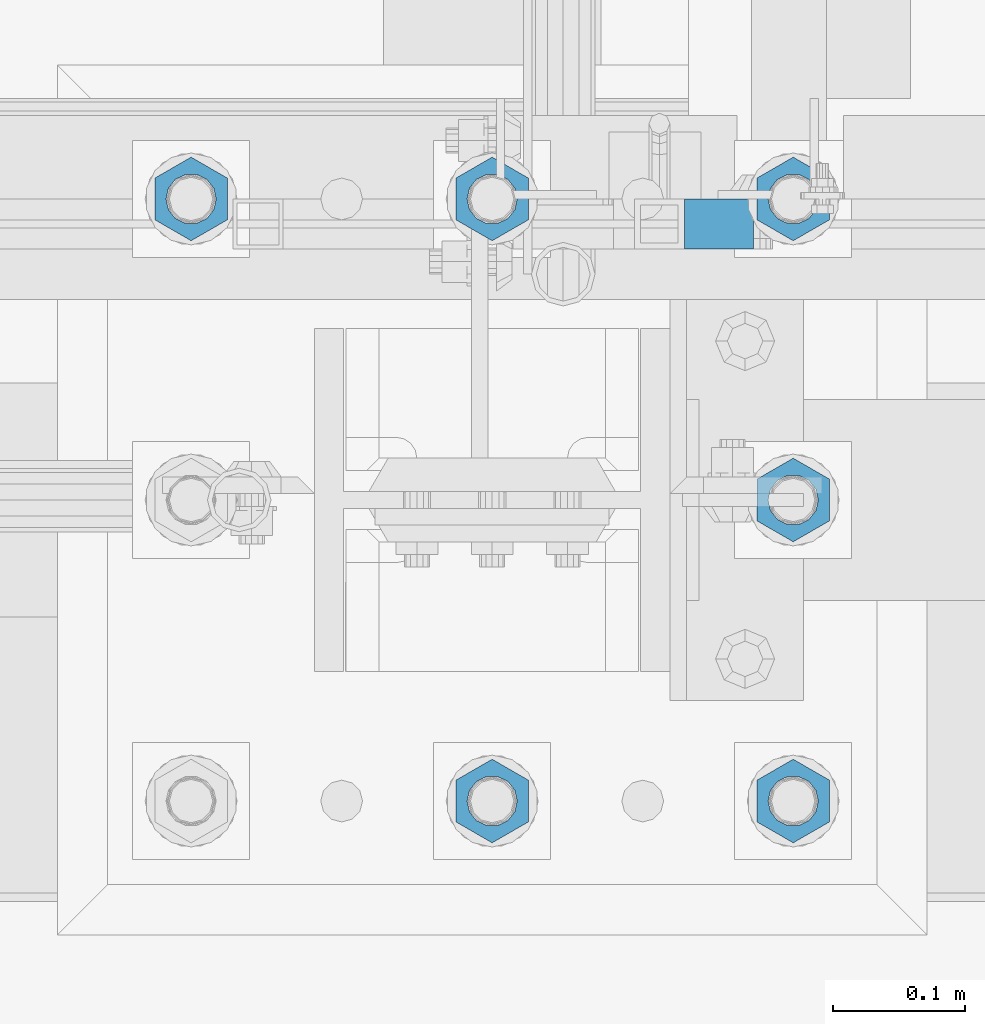
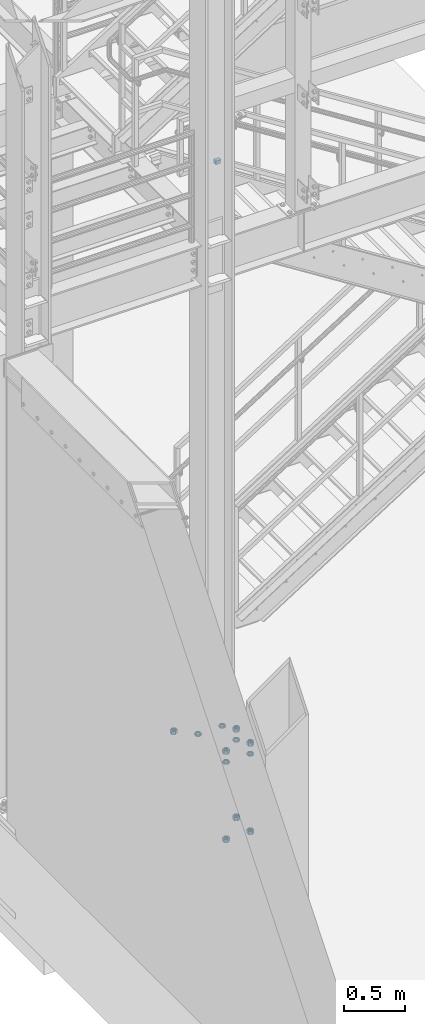
# One storey, part 1384 of 1876: 13 beams, 2 elements without a shape of their own.
"""IFC2X3 building model written with IfcOpenShell, lengths in millimetres."""

from ifc_helpers import new_model, si_unit, frame, origin_with_axes, place, context, subcontext, project, spatial, faceted_brep, material, type_object, element, aggregate, save


model = new_model("IFC2X3")

# Units and contexts
model_context = context("Model", 3, precision=1e-05, world=origin_with_axes())
body_context = subcontext(model_context, "Body", "Model", "MODEL_VIEW")
ifc_project = project(units=[si_unit("LENGTHUNIT", "METRE", prefix="MILLI"), si_unit("AREAUNIT", "SQUARE_METRE"), si_unit("VOLUMEUNIT", "CUBIC_METRE"), si_unit("MASSUNIT", "GRAM", prefix="KILO"), si_unit("TIMEUNIT", "SECOND"), si_unit("PLANEANGLEUNIT", "RADIAN"), si_unit("SOLIDANGLEUNIT", "STERADIAN"), si_unit("THERMODYNAMICTEMPERATUREUNIT", "DEGREE_CELSIUS"), si_unit("LUMINOUSINTENSITYUNIT", "LUMEN")], contexts=[model_context])

# Site, building, storey
site_placement = place(None, origin_with_axes())
site = spatial("IfcSite", under=ifc_project, at=site_placement, CompositionType="ELEMENT")
building_placement = place(site_placement, origin_with_axes())
building = spatial("IfcBuilding", under=site, at=building_placement, Name="Undefined", CompositionType="ELEMENT")
storey_placement = place(building_placement, origin_with_axes())
storey = spatial("IfcBuildingStorey", under=building, at=storey_placement, Name="Undefined", CompositionType="ELEMENT", Elevation=0.0)

# Assembly, beam
assembly_1_placement = place(storey_placement, origin_with_axes())
assembly_1 = element("IfcElementAssembly", 1, at=assembly_1_placement, inside=storey, Name="RAIL", AssemblyPlace="NOTDEFINED", PredefinedType="RIGID_FRAME")
ifc_material_1 = material()
beam_type_1 = type_object("IfcBeamType", Name="HSS1-1/2X1-1/2X1/8", PredefinedType="NOTDEFINED")
beam_1_placement = place(assembly_1_placement, frame((1920.01408941646, -6902.45000114554, 5673.72500000168), z_axis=(0.0, 0.0, 1.0), x_axis=(-1.0, 0.0, 0.0)))
beam_1 = element("IfcBeam", 2, at=beam_1_placement, type_object=beam_type_1, material=ifc_material_1, Name="RAIL", ObjectType="HSS1-1/2X1-1/2X1/8", context=body_context, shape_type="Brep", body=[
    faceted_brep([(4.61079483309095, 15.8749992829999, -15.8749992829999), (4.61079483309095, -15.8749992829999, -15.8749992829999), (46.7640840715421, -15.8749992829999, -15.8749992829999), (46.7640840715421, 15.8749992829999, -15.8749992829999), (-4.61079482670993, -15.8749992829999, 15.8749992829999), (46.7640840715421, -15.8749992829999, 15.8749992829999), (-4.61079482670993, 15.8749992829999, 15.8749992829999), (46.7640840715421, 15.8749992829999, 15.8749992829999), (5.5329538267797, 19.0499992349996, -19.0499992350001), (-5.53295382039778, 19.0499992349996, 19.0499992350001), (46.7640840715421, 19.0499992349996, 19.0499992349996), (46.7640840715421, 19.0499992349996, -19.0499992349996), (-5.53295382039778, -19.0499992349996, 19.0499992350001), (46.7640840715421, -19.0499992349996, 19.0499992349996), (5.5329538267797, -19.0499992349996, -19.0499992350001), (46.7640840715421, -19.0499992349996, -19.0499992349996)], [[[0, 1, 2, 3]], [[1, 4, 5, 2]], [[4, 6, 7, 5]], [[6, 0, 3, 7]], [[8, 9, 10, 11]], [[9, 12, 13, 10]], [[12, 14, 15, 13]], [[14, 8, 11, 15]], [[13, 15, 11, 10], [5, 7, 3, 2]], [[14, 12, 9, 8], [6, 4, 1, 0]]]),
])
aggregate(assembly_1, [beam_1])

# Assembly, beams
assembly_2_placement = place(storey_placement, origin_with_axes())
assembly_2 = element("IfcElementAssembly", 3, at=assembly_2_placement, inside=storey, Name="TEMPLATE", AssemblyPlace="NOTDEFINED", PredefinedType="RIGID_FRAME")
ifc_material_2 = material(Name="STEEL/A563")
beam_type_2 = type_object("IfcBeamType", Name="1-3/8_DIA. HALF_NUT", PredefinedType="NOTDEFINED")
beam_2_placement = place(assembly_2_placement, frame((1727.2, -6883.4, 33.3375), z_axis=(-1.0, 0.0, 0.0), x_axis=(0.0, 0.0, -1.0)))
beam_2 = element("IfcBeam", 4, at=beam_2_placement, type_object=beam_type_2, material=ifc_material_2, Name="NUT", ObjectType="1-3/8_DIA. HALF_NUT", context=body_context, shape_type="Brep", body=[
    faceted_brep([(0.0, -31.75, 0.0), (0.0, -15.8800001144409, -27.5), (17.4625, -15.8800001144409, -27.5), (17.4625, -31.75, 0.0), (0.0, 15.8800001144409, -27.5), (17.4625, 15.8800001144409, -27.5), (0.0, 31.75, 0.0), (17.4625, 31.75, 0.0), (0.0, 15.8800001144409, 27.5), (17.4625, 15.8800001144409, 27.5), (0.0, -15.8800001144409, 27.5), (17.4625, -15.8800001144409, 27.5), (0.0, 0.0, 19.0499999999993), (0.0, 8.2654848991624, 17.1634562461559), (17.4625, 8.2654848991624, 17.1634562461559), (17.4625, 0.0, 19.0499992370605), (0.0, 14.8938891445259, 11.8774802497237), (17.4625, 14.8938891445259, 11.8774802497237), (0.0, 18.5723759832526, 4.2390236220981), (17.4625, 18.5723759832526, 4.2390236220981), (0.0, 18.5723759832526, -4.2390236220981), (17.4625, 18.5723759832526, -4.2390236220981), (0.0, 14.8938891445259, -11.8774802497237), (17.4625, 14.8938891445259, -11.8774802497237), (0.0, 8.2654848991624, -17.1634562461568), (17.4625, 8.2654848991624, -17.1634562461568), (0.0, 0.0, -19.05), (17.4625, 0.0, -19.0499992370605), (0.0, -8.2654848991624, -17.1634562461559), (17.4625, -8.2654848991624, -17.1634562461559), (0.0, -14.8938891445259, -11.8774802497237), (17.4625, -14.8938891445259, -11.8774802497237), (0.0, -18.5723759832526, -4.2390236220981), (17.4625, -18.5723759832526, -4.2390236220981), (0.0, -18.5723759832526, 4.2390236220981), (17.4625, -18.5723759832526, 4.2390236220981), (0.0, -14.8938891445259, 11.8774802497237), (17.4625, -14.8938891445259, 11.8774802497237), (0.0, -8.2654848991624, 17.1634562461568), (17.4625, -8.2654848991624, 17.1634562461568)], [[[0, 1, 2, 3]], [[1, 4, 5, 2]], [[4, 6, 7, 5]], [[6, 8, 9, 7]], [[8, 10, 11, 9]], [[10, 0, 3, 11]], [[12, 13, 14, 15]], [[13, 16, 17, 14]], [[16, 18, 19, 17]], [[18, 20, 21, 19]], [[20, 22, 23, 21]], [[22, 24, 25, 23]], [[24, 26, 27, 25]], [[26, 28, 29, 27]], [[28, 30, 31, 29]], [[30, 32, 33, 31]], [[32, 34, 35, 33]], [[34, 36, 37, 35]], [[36, 38, 39, 37]], [[38, 12, 15, 39]], [[5, 7, 9, 11, 3, 2], [17, 19, 21, 23, 25, 27, 29, 31, 33, 35, 37, 39, 15, 14]], [[10, 8, 6, 4, 1, 0], [38, 36, 34, 32, 30, 28, 26, 24, 22, 20, 18, 16, 13, 12]]]),
])
beam_3_placement = place(assembly_2_placement, frame((1955.8, -6883.4, 33.3375), z_axis=(-1.0, 0.0, 0.0), x_axis=(0.0, 0.0, -1.0)))
beam_3 = element("IfcBeam", 5, at=beam_3_placement, type_object=beam_type_2, material=ifc_material_2, Name="NUT", ObjectType="1-3/8_DIA. HALF_NUT", context=body_context, shape_type="Brep", body=[
    faceted_brep([(0.0, -31.75, 0.0), (0.0, -15.8800001144409, -27.5), (17.4625, -15.8800001144409, -27.5), (17.4625, -31.75, 0.0), (0.0, 15.8800001144409, -27.5), (17.4625, 15.8800001144409, -27.5), (0.0, 31.75, 0.0), (17.4625, 31.75, 0.0), (0.0, 15.8800001144409, 27.5), (17.4625, 15.8800001144409, 27.5), (0.0, -15.8800001144409, 27.5), (17.4625, -15.8800001144409, 27.5), (0.0, 0.0, 19.0499999999993), (0.0, 8.2654848991624, 17.1634562461559), (17.4625, 8.2654848991624, 17.1634562461559), (17.4625, 0.0, 19.0499992370605), (0.0, 14.8938891445259, 11.8774802497237), (17.4625, 14.8938891445259, 11.8774802497237), (0.0, 18.5723759832526, 4.2390236220981), (17.4625, 18.5723759832526, 4.2390236220981), (0.0, 18.5723759832526, -4.2390236220981), (17.4625, 18.5723759832526, -4.2390236220981), (0.0, 14.8938891445259, -11.8774802497237), (17.4625, 14.8938891445259, -11.8774802497237), (0.0, 8.2654848991624, -17.1634562461568), (17.4625, 8.2654848991624, -17.1634562461568), (0.0, 0.0, -19.05), (17.4625, 0.0, -19.0499992370605), (0.0, -8.2654848991624, -17.1634562461559), (17.4625, -8.2654848991624, -17.1634562461559), (0.0, -14.8938891445259, -11.8774802497237), (17.4625, -14.8938891445259, -11.8774802497237), (0.0, -18.5723759832526, -4.2390236220981), (17.4625, -18.5723759832526, -4.2390236220981), (0.0, -18.5723759832526, 4.2390236220981), (17.4625, -18.5723759832526, 4.2390236220981), (0.0, -14.8938891445259, 11.8774802497237), (17.4625, -14.8938891445259, 11.8774802497237), (0.0, -8.2654848991624, 17.1634562461568), (17.4625, -8.2654848991624, 17.1634562461568)], [[[0, 1, 2, 3]], [[1, 4, 5, 2]], [[4, 6, 7, 5]], [[6, 8, 9, 7]], [[8, 10, 11, 9]], [[10, 0, 3, 11]], [[12, 13, 14, 15]], [[13, 16, 17, 14]], [[16, 18, 19, 17]], [[18, 20, 21, 19]], [[20, 22, 23, 21]], [[22, 24, 25, 23]], [[24, 26, 27, 25]], [[26, 28, 29, 27]], [[28, 30, 31, 29]], [[30, 32, 33, 31]], [[32, 34, 35, 33]], [[34, 36, 37, 35]], [[36, 38, 39, 37]], [[38, 12, 15, 39]], [[5, 7, 9, 11, 3, 2], [17, 19, 21, 23, 25, 27, 29, 31, 33, 35, 37, 39, 15, 14]], [[10, 8, 6, 4, 1, 0], [38, 36, 34, 32, 30, 28, 26, 24, 22, 20, 18, 16, 13, 12]]]),
])
beam_4_placement = place(assembly_2_placement, frame((1955.8, -7112.0, 33.3375), z_axis=(1.0, 0.0, 0.0), x_axis=(0.0, 0.0, -1.0)))
beam_4 = element("IfcBeam", 6, at=beam_4_placement, type_object=beam_type_2, material=ifc_material_2, Name="NUT", ObjectType="1-3/8_DIA. HALF_NUT", context=body_context, shape_type="Brep", body=[
    faceted_brep([(0.0, -31.75, 0.0), (0.0, -15.8800001144409, -27.5), (17.4625, -15.8800001144409, -27.5), (17.4625, -31.75, 0.0), (0.0, 15.8800001144409, -27.5), (17.4625, 15.8800001144409, -27.5), (0.0, 31.75, 0.0), (17.4625, 31.75, 0.0), (0.0, 15.8800001144409, 27.5), (17.4625, 15.8800001144409, 27.5), (0.0, -15.8800001144409, 27.5), (17.4625, -15.8800001144409, 27.5), (0.0, 0.0, 19.0499999999993), (0.0, 8.2654848991624, 17.1634562461559), (17.4625, 8.2654848991624, 17.1634562461559), (17.4625, 0.0, 19.0499992370605), (0.0, 14.8938891445259, 11.8774802497237), (17.4625, 14.8938891445259, 11.8774802497237), (0.0, 18.5723759832526, 4.2390236220981), (17.4625, 18.5723759832526, 4.2390236220981), (0.0, 18.5723759832526, -4.2390236220981), (17.4625, 18.5723759832526, -4.2390236220981), (0.0, 14.8938891445259, -11.8774802497237), (17.4625, 14.8938891445259, -11.8774802497237), (0.0, 8.2654848991624, -17.1634562461568), (17.4625, 8.2654848991624, -17.1634562461568), (0.0, 0.0, -19.05), (17.4625, 0.0, -19.0499992370605), (0.0, -8.2654848991624, -17.1634562461559), (17.4625, -8.2654848991624, -17.1634562461559), (0.0, -14.8938891445259, -11.8774802497237), (17.4625, -14.8938891445259, -11.8774802497237), (0.0, -18.5723759832526, -4.2390236220981), (17.4625, -18.5723759832526, -4.2390236220981), (0.0, -18.5723759832526, 4.2390236220981), (17.4625, -18.5723759832526, 4.2390236220981), (0.0, -14.8938891445259, 11.8774802497237), (17.4625, -14.8938891445259, 11.8774802497237), (0.0, -8.2654848991624, 17.1634562461568), (17.4625, -8.2654848991624, 17.1634562461568)], [[[0, 1, 2, 3]], [[1, 4, 5, 2]], [[4, 6, 7, 5]], [[6, 8, 9, 7]], [[8, 10, 11, 9]], [[10, 0, 3, 11]], [[12, 13, 14, 15]], [[13, 16, 17, 14]], [[16, 18, 19, 17]], [[18, 20, 21, 19]], [[20, 22, 23, 21]], [[22, 24, 25, 23]], [[24, 26, 27, 25]], [[26, 28, 29, 27]], [[28, 30, 31, 29]], [[30, 32, 33, 31]], [[32, 34, 35, 33]], [[34, 36, 37, 35]], [[36, 38, 39, 37]], [[38, 12, 15, 39]], [[5, 7, 9, 11, 3, 2], [17, 19, 21, 23, 25, 27, 29, 31, 33, 35, 37, 39, 15, 14]], [[10, 8, 6, 4, 1, 0], [38, 36, 34, 32, 30, 28, 26, 24, 22, 20, 18, 16, 13, 12]]]),
])
beam_5_placement = place(assembly_2_placement, frame((1955.8, -7340.6, 33.3375), z_axis=(1.0, 0.0, 0.0), x_axis=(0.0, 0.0, -1.0)))
beam_5 = element("IfcBeam", 7, at=beam_5_placement, type_object=beam_type_2, material=ifc_material_2, Name="NUT", ObjectType="1-3/8_DIA. HALF_NUT", context=body_context, shape_type="Brep", body=[
    faceted_brep([(0.0, -31.75, 0.0), (0.0, -15.8800001144409, -27.5), (17.4625, -15.8800001144409, -27.5), (17.4625, -31.75, 0.0), (0.0, 15.8800001144409, -27.5), (17.4625, 15.8800001144409, -27.5), (0.0, 31.75, 0.0), (17.4625, 31.75, 0.0), (0.0, 15.8800001144409, 27.5), (17.4625, 15.8800001144409, 27.5), (0.0, -15.8800001144409, 27.5), (17.4625, -15.8800001144409, 27.5), (0.0, 0.0, 19.0499999999993), (0.0, 8.2654848991624, 17.1634562461559), (17.4625, 8.2654848991624, 17.1634562461559), (17.4625, 0.0, 19.0499992370605), (0.0, 14.8938891445259, 11.8774802497237), (17.4625, 14.8938891445259, 11.8774802497237), (0.0, 18.5723759832526, 4.2390236220981), (17.4625, 18.5723759832526, 4.2390236220981), (0.0, 18.5723759832526, -4.2390236220981), (17.4625, 18.5723759832526, -4.2390236220981), (0.0, 14.8938891445259, -11.8774802497237), (17.4625, 14.8938891445259, -11.8774802497237), (0.0, 8.2654848991624, -17.1634562461568), (17.4625, 8.2654848991624, -17.1634562461568), (0.0, 0.0, -19.05), (17.4625, 0.0, -19.0499992370605), (0.0, -8.2654848991624, -17.1634562461559), (17.4625, -8.2654848991624, -17.1634562461559), (0.0, -14.8938891445259, -11.8774802497237), (17.4625, -14.8938891445259, -11.8774802497237), (0.0, -18.5723759832526, -4.2390236220981), (17.4625, -18.5723759832526, -4.2390236220981), (0.0, -18.5723759832526, 4.2390236220981), (17.4625, -18.5723759832526, 4.2390236220981), (0.0, -14.8938891445259, 11.8774802497237), (17.4625, -14.8938891445259, 11.8774802497237), (0.0, -8.2654848991624, 17.1634562461568), (17.4625, -8.2654848991624, 17.1634562461568)], [[[0, 1, 2, 3]], [[1, 4, 5, 2]], [[4, 6, 7, 5]], [[6, 8, 9, 7]], [[8, 10, 11, 9]], [[10, 0, 3, 11]], [[12, 13, 14, 15]], [[13, 16, 17, 14]], [[16, 18, 19, 17]], [[18, 20, 21, 19]], [[20, 22, 23, 21]], [[22, 24, 25, 23]], [[24, 26, 27, 25]], [[26, 28, 29, 27]], [[28, 30, 31, 29]], [[30, 32, 33, 31]], [[32, 34, 35, 33]], [[34, 36, 37, 35]], [[36, 38, 39, 37]], [[38, 12, 15, 39]], [[5, 7, 9, 11, 3, 2], [17, 19, 21, 23, 25, 27, 29, 31, 33, 35, 37, 39, 15, 14]], [[10, 8, 6, 4, 1, 0], [38, 36, 34, 32, 30, 28, 26, 24, 22, 20, 18, 16, 13, 12]]]),
])
beam_6_placement = place(assembly_2_placement, frame((1727.2, -7340.6, 33.3375), z_axis=(1.0, 0.0, 0.0), x_axis=(0.0, 0.0, -1.0)))
beam_6 = element("IfcBeam", 8, at=beam_6_placement, type_object=beam_type_2, material=ifc_material_2, Name="NUT", ObjectType="1-3/8_DIA. HALF_NUT", context=body_context, shape_type="Brep", body=[
    faceted_brep([(0.0, -31.75, 0.0), (0.0, -15.8800001144409, -27.5), (17.4625, -15.8800001144409, -27.5), (17.4625, -31.75, 0.0), (0.0, 15.8800001144409, -27.5), (17.4625, 15.8800001144409, -27.5), (0.0, 31.75, 0.0), (17.4625, 31.75, 0.0), (0.0, 15.8800001144409, 27.5), (17.4625, 15.8800001144409, 27.5), (0.0, -15.8800001144409, 27.5), (17.4625, -15.8800001144409, 27.5), (0.0, 0.0, 19.0499999999993), (0.0, 8.2654848991624, 17.1634562461559), (17.4625, 8.2654848991624, 17.1634562461559), (17.4625, 0.0, 19.0499992370605), (0.0, 14.8938891445259, 11.8774802497237), (17.4625, 14.8938891445259, 11.8774802497237), (0.0, 18.5723759832526, 4.2390236220981), (17.4625, 18.5723759832526, 4.2390236220981), (0.0, 18.5723759832526, -4.2390236220981), (17.4625, 18.5723759832526, -4.2390236220981), (0.0, 14.8938891445259, -11.8774802497237), (17.4625, 14.8938891445259, -11.8774802497237), (0.0, 8.2654848991624, -17.1634562461568), (17.4625, 8.2654848991624, -17.1634562461568), (0.0, 0.0, -19.05), (17.4625, 0.0, -19.0499992370605), (0.0, -8.2654848991624, -17.1634562461559), (17.4625, -8.2654848991624, -17.1634562461559), (0.0, -14.8938891445259, -11.8774802497237), (17.4625, -14.8938891445259, -11.8774802497237), (0.0, -18.5723759832526, -4.2390236220981), (17.4625, -18.5723759832526, -4.2390236220981), (0.0, -18.5723759832526, 4.2390236220981), (17.4625, -18.5723759832526, 4.2390236220981), (0.0, -14.8938891445259, 11.8774802497237), (17.4625, -14.8938891445259, 11.8774802497237), (0.0, -8.2654848991624, 17.1634562461568), (17.4625, -8.2654848991624, 17.1634562461568)], [[[0, 1, 2, 3]], [[1, 4, 5, 2]], [[4, 6, 7, 5]], [[6, 8, 9, 7]], [[8, 10, 11, 9]], [[10, 0, 3, 11]], [[12, 13, 14, 15]], [[13, 16, 17, 14]], [[16, 18, 19, 17]], [[18, 20, 21, 19]], [[20, 22, 23, 21]], [[22, 24, 25, 23]], [[24, 26, 27, 25]], [[26, 28, 29, 27]], [[28, 30, 31, 29]], [[30, 32, 33, 31]], [[32, 34, 35, 33]], [[34, 36, 37, 35]], [[36, 38, 39, 37]], [[38, 12, 15, 39]], [[5, 7, 9, 11, 3, 2], [17, 19, 21, 23, 25, 27, 29, 31, 33, 35, 37, 39, 15, 14]], [[10, 8, 6, 4, 1, 0], [38, 36, 34, 32, 30, 28, 26, 24, 22, 20, 18, 16, 13, 12]]]),
])
beam_type_3 = type_object("IfcBeamType", Name="1-3/8_HEAVY_HEX_NUT", PredefinedType="NOTDEFINED")
beam_7_placement = place(assembly_2_placement, frame((1955.80001220703, -7340.6, -727.074998474121), z_axis=(1.0, 0.0, 0.0), x_axis=(0.0, 0.0, -1.0)))
beam_7 = element("IfcBeam", 9, at=beam_7_placement, type_object=beam_type_3, material=ifc_material_2, Name="NUT", ObjectType="1-3/8_HEAVY_HEX_NUT", context=body_context, shape_type="Brep", body=[
    faceted_brep([(0.0, -31.75, 0.0), (0.0, -15.8800001144409, -27.5), (34.925, -15.8800001144409, -27.5), (34.925, -31.75, 0.0), (0.0, 15.8800001144409, -27.5), (34.925, 15.8800001144409, -27.5), (0.0, 31.75, 0.0), (34.925, 31.75, 0.0), (0.0, 15.8800001144409, 27.5), (34.925, 15.8800001144409, 27.5), (0.0, -15.8800001144409, 27.5), (34.925, -15.8800001144409, 27.5), (0.0, 0.0, 19.0499999999993), (0.0, 8.2654848991624, 17.1634562461559), (34.925, 8.26548489916252, 17.163456246155), (34.925, 0.0, 19.0499992370605), (0.0, 14.8938891445259, 11.8774802497237), (34.925, 14.8938891445259, 11.8774802497246), (0.0, 18.5723759832526, 4.2390236220981), (34.925, 18.5723759832528, 4.23902362209628), (0.0, 18.5723759832526, -4.2390236220981), (34.925, 18.5723759832528, -4.23902362209628), (0.0, 14.8938891445259, -11.8774802497237), (34.925, 14.8938891445259, -11.8774802497246), (0.0, 8.2654848991624, -17.1634562461568), (34.925, 8.26548489916252, -17.163456246155), (0.0, 0.0, -19.05), (34.925, 0.0, -19.0499992370605), (0.0, -8.2654848991624, -17.1634562461559), (34.925, -8.26548489916252, -17.163456246155), (0.0, -14.8938891445259, -11.8774802497237), (34.925, -14.8938891445259, -11.8774802497246), (0.0, -18.5723759832526, -4.2390236220981), (34.925, -18.5723759832528, -4.23902362209628), (0.0, -18.5723759832526, 4.2390236220981), (34.925, -18.5723759832528, 4.23902362209628), (0.0, -14.8938891445259, 11.8774802497237), (34.925, -14.8938891445259, 11.8774802497246), (0.0, -8.2654848991624, 17.1634562461568), (34.925, -8.26548489916252, 17.163456246155)], [[[0, 1, 2, 3]], [[1, 4, 5, 2]], [[4, 6, 7, 5]], [[6, 8, 9, 7]], [[8, 10, 11, 9]], [[10, 0, 3, 11]], [[12, 13, 14, 15]], [[13, 16, 17, 14]], [[16, 18, 19, 17]], [[18, 20, 21, 19]], [[20, 22, 23, 21]], [[22, 24, 25, 23]], [[24, 26, 27, 25]], [[26, 28, 29, 27]], [[28, 30, 31, 29]], [[30, 32, 33, 31]], [[32, 34, 35, 33]], [[34, 36, 37, 35]], [[36, 38, 39, 37]], [[38, 12, 15, 39]], [[5, 7, 9, 11, 3, 2], [17, 19, 21, 23, 25, 27, 29, 31, 33, 35, 37, 39, 15, 14]], [[10, 8, 6, 4, 1, 0], [38, 36, 34, 32, 30, 28, 26, 24, 22, 20, 18, 16, 13, 12]]]),
])
beam_8_placement = place(assembly_2_placement, frame((1955.80001220703, -7112.0, -727.074998474121), z_axis=(1.0, 0.0, 0.0), x_axis=(0.0, 0.0, -1.0)))
beam_8 = element("IfcBeam", 10, at=beam_8_placement, type_object=beam_type_3, material=ifc_material_2, Name="NUT", ObjectType="1-3/8_HEAVY_HEX_NUT", context=body_context, shape_type="Brep", body=[
    faceted_brep([(0.0, -31.75, 0.0), (0.0, -15.8800001144409, -27.5), (34.925, -15.8800001144409, -27.5), (34.925, -31.75, 0.0), (0.0, 15.8800001144409, -27.5), (34.925, 15.8800001144409, -27.5), (0.0, 31.75, 0.0), (34.925, 31.75, 0.0), (0.0, 15.8800001144409, 27.5), (34.925, 15.8800001144409, 27.5), (0.0, -15.8800001144409, 27.5), (34.925, -15.8800001144409, 27.5), (0.0, 0.0, 19.0499999999993), (0.0, 8.2654848991624, 17.1634562461559), (34.925, 8.26548489916252, 17.163456246155), (34.925, 0.0, 19.0499992370605), (0.0, 14.8938891445259, 11.8774802497237), (34.925, 14.8938891445259, 11.8774802497246), (0.0, 18.5723759832526, 4.2390236220981), (34.925, 18.5723759832528, 4.23902362209628), (0.0, 18.5723759832526, -4.2390236220981), (34.925, 18.5723759832528, -4.23902362209628), (0.0, 14.8938891445259, -11.8774802497237), (34.925, 14.8938891445259, -11.8774802497246), (0.0, 8.2654848991624, -17.1634562461568), (34.925, 8.26548489916252, -17.163456246155), (0.0, 0.0, -19.05), (34.925, 0.0, -19.0499992370605), (0.0, -8.2654848991624, -17.1634562461559), (34.925, -8.26548489916252, -17.163456246155), (0.0, -14.8938891445259, -11.8774802497237), (34.925, -14.8938891445259, -11.8774802497246), (0.0, -18.5723759832526, -4.2390236220981), (34.925, -18.5723759832528, -4.23902362209628), (0.0, -18.5723759832526, 4.2390236220981), (34.925, -18.5723759832528, 4.23902362209628), (0.0, -14.8938891445259, 11.8774802497237), (34.925, -14.8938891445259, 11.8774802497246), (0.0, -8.2654848991624, 17.1634562461568), (34.925, -8.26548489916252, 17.163456246155)], [[[0, 1, 2, 3]], [[1, 4, 5, 2]], [[4, 6, 7, 5]], [[6, 8, 9, 7]], [[8, 10, 11, 9]], [[10, 0, 3, 11]], [[12, 13, 14, 15]], [[13, 16, 17, 14]], [[16, 18, 19, 17]], [[18, 20, 21, 19]], [[20, 22, 23, 21]], [[22, 24, 25, 23]], [[24, 26, 27, 25]], [[26, 28, 29, 27]], [[28, 30, 31, 29]], [[30, 32, 33, 31]], [[32, 34, 35, 33]], [[34, 36, 37, 35]], [[36, 38, 39, 37]], [[38, 12, 15, 39]], [[5, 7, 9, 11, 3, 2], [17, 19, 21, 23, 25, 27, 29, 31, 33, 35, 37, 39, 15, 14]], [[10, 8, 6, 4, 1, 0], [38, 36, 34, 32, 30, 28, 26, 24, 22, 20, 18, 16, 13, 12]]]),
])
beam_9_placement = place(assembly_2_placement, frame((1727.20001220703, -7340.6, -727.074998474121), z_axis=(1.0, 0.0, 0.0), x_axis=(0.0, 0.0, -1.0)))
beam_9 = element("IfcBeam", 11, at=beam_9_placement, type_object=beam_type_3, material=ifc_material_2, Name="NUT", ObjectType="1-3/8_HEAVY_HEX_NUT", context=body_context, shape_type="Brep", body=[
    faceted_brep([(0.0, -31.75, 0.0), (0.0, -15.8800001144409, -27.5), (34.925, -15.8800001144409, -27.5), (34.925, -31.75, 0.0), (0.0, 15.8800001144409, -27.5), (34.925, 15.8800001144409, -27.5), (0.0, 31.75, 0.0), (34.925, 31.75, 0.0), (0.0, 15.8800001144409, 27.5), (34.925, 15.8800001144409, 27.5), (0.0, -15.8800001144409, 27.5), (34.925, -15.8800001144409, 27.5), (0.0, 0.0, 19.0499999999993), (0.0, 8.2654848991624, 17.1634562461559), (34.925, 8.26548489916252, 17.163456246155), (34.925, 0.0, 19.0499992370605), (0.0, 14.8938891445259, 11.8774802497237), (34.925, 14.8938891445259, 11.8774802497246), (0.0, 18.5723759832526, 4.2390236220981), (34.925, 18.5723759832528, 4.23902362209628), (0.0, 18.5723759832526, -4.2390236220981), (34.925, 18.5723759832528, -4.23902362209628), (0.0, 14.8938891445259, -11.8774802497237), (34.925, 14.8938891445259, -11.8774802497246), (0.0, 8.2654848991624, -17.1634562461568), (34.925, 8.26548489916252, -17.163456246155), (0.0, 0.0, -19.05), (34.925, 0.0, -19.0499992370605), (0.0, -8.2654848991624, -17.1634562461559), (34.925, -8.26548489916252, -17.163456246155), (0.0, -14.8938891445259, -11.8774802497237), (34.925, -14.8938891445259, -11.8774802497246), (0.0, -18.5723759832526, -4.2390236220981), (34.925, -18.5723759832528, -4.23902362209628), (0.0, -18.5723759832526, 4.2390236220981), (34.925, -18.5723759832528, 4.23902362209628), (0.0, -14.8938891445259, 11.8774802497237), (34.925, -14.8938891445259, 11.8774802497246), (0.0, -8.2654848991624, 17.1634562461568), (34.925, -8.26548489916252, 17.163456246155)], [[[0, 1, 2, 3]], [[1, 4, 5, 2]], [[4, 6, 7, 5]], [[6, 8, 9, 7]], [[8, 10, 11, 9]], [[10, 0, 3, 11]], [[12, 13, 14, 15]], [[13, 16, 17, 14]], [[16, 18, 19, 17]], [[18, 20, 21, 19]], [[20, 22, 23, 21]], [[22, 24, 25, 23]], [[24, 26, 27, 25]], [[26, 28, 29, 27]], [[28, 30, 31, 29]], [[30, 32, 33, 31]], [[32, 34, 35, 33]], [[34, 36, 37, 35]], [[36, 38, 39, 37]], [[38, 12, 15, 39]], [[5, 7, 9, 11, 3, 2], [17, 19, 21, 23, 25, 27, 29, 31, 33, 35, 37, 39, 15, 14]], [[10, 8, 6, 4, 1, 0], [38, 36, 34, 32, 30, 28, 26, 24, 22, 20, 18, 16, 13, 12]]]),
])
beam_10_placement = place(assembly_2_placement, frame((1955.8, -7340.6, 150.8125), z_axis=(1.0, 0.0, 0.0), x_axis=(0.0, 0.0, -1.0)))
beam_10 = element("IfcBeam", 12, at=beam_10_placement, type_object=beam_type_3, material=ifc_material_2, Name="NUT", ObjectType="1-3/8_HEAVY_HEX_NUT", context=body_context, shape_type="Brep", body=[
    faceted_brep([(0.0, -31.75, 0.0), (0.0, -15.8800001144409, -27.5), (34.925, -15.8800001144409, -27.5), (34.925, -31.75, 0.0), (0.0, 15.8800001144409, -27.5), (34.925, 15.8800001144409, -27.5), (0.0, 31.75, 0.0), (34.925, 31.75, 0.0), (0.0, 15.8800001144409, 27.5), (34.925, 15.8800001144409, 27.5), (0.0, -15.8800001144409, 27.5), (34.925, -15.8800001144409, 27.5), (0.0, 0.0, 19.0499999999993), (0.0, 8.2654848991624, 17.1634562461559), (34.925, 8.26548489916252, 17.163456246155), (34.925, 0.0, 19.0499992370605), (0.0, 14.8938891445259, 11.8774802497237), (34.925, 14.8938891445259, 11.8774802497246), (0.0, 18.5723759832526, 4.2390236220981), (34.925, 18.5723759832528, 4.23902362209628), (0.0, 18.5723759832526, -4.2390236220981), (34.925, 18.5723759832528, -4.23902362209628), (0.0, 14.8938891445259, -11.8774802497237), (34.925, 14.8938891445259, -11.8774802497246), (0.0, 8.2654848991624, -17.1634562461568), (34.925, 8.26548489916252, -17.163456246155), (0.0, 0.0, -19.05), (34.925, 0.0, -19.0499992370605), (0.0, -8.2654848991624, -17.1634562461559), (34.925, -8.26548489916252, -17.163456246155), (0.0, -14.8938891445259, -11.8774802497237), (34.925, -14.8938891445259, -11.8774802497246), (0.0, -18.5723759832526, -4.2390236220981), (34.925, -18.5723759832528, -4.23902362209628), (0.0, -18.5723759832526, 4.2390236220981), (34.925, -18.5723759832528, 4.23902362209628), (0.0, -14.8938891445259, 11.8774802497237), (34.925, -14.8938891445259, 11.8774802497246), (0.0, -8.2654848991624, 17.1634562461568), (34.925, -8.26548489916252, 17.163456246155)], [[[0, 1, 2, 3]], [[1, 4, 5, 2]], [[4, 6, 7, 5]], [[6, 8, 9, 7]], [[8, 10, 11, 9]], [[10, 0, 3, 11]], [[12, 13, 14, 15]], [[13, 16, 17, 14]], [[16, 18, 19, 17]], [[18, 20, 21, 19]], [[20, 22, 23, 21]], [[22, 24, 25, 23]], [[24, 26, 27, 25]], [[26, 28, 29, 27]], [[28, 30, 31, 29]], [[30, 32, 33, 31]], [[32, 34, 35, 33]], [[34, 36, 37, 35]], [[36, 38, 39, 37]], [[38, 12, 15, 39]], [[5, 7, 9, 11, 3, 2], [17, 19, 21, 23, 25, 27, 29, 31, 33, 35, 37, 39, 15, 14]], [[10, 8, 6, 4, 1, 0], [38, 36, 34, 32, 30, 28, 26, 24, 22, 20, 18, 16, 13, 12]]]),
])
beam_11_placement = place(assembly_2_placement, frame((1955.8, -7112.0, 150.8125), z_axis=(1.0, 0.0, 0.0), x_axis=(0.0, 0.0, -1.0)))
beam_11 = element("IfcBeam", 13, at=beam_11_placement, type_object=beam_type_3, material=ifc_material_2, Name="NUT", ObjectType="1-3/8_HEAVY_HEX_NUT", context=body_context, shape_type="Brep", body=[
    faceted_brep([(0.0, -31.75, 0.0), (0.0, -15.8800001144409, -27.5), (34.925, -15.8800001144409, -27.5), (34.925, -31.75, 0.0), (0.0, 15.8800001144409, -27.5), (34.925, 15.8800001144409, -27.5), (0.0, 31.75, 0.0), (34.925, 31.75, 0.0), (0.0, 15.8800001144409, 27.5), (34.925, 15.8800001144409, 27.5), (0.0, -15.8800001144409, 27.5), (34.925, -15.8800001144409, 27.5), (0.0, 0.0, 19.0499999999993), (0.0, 8.2654848991624, 17.1634562461559), (34.925, 8.26548489916252, 17.163456246155), (34.925, 0.0, 19.0499992370605), (0.0, 14.8938891445259, 11.8774802497237), (34.925, 14.8938891445259, 11.8774802497246), (0.0, 18.5723759832526, 4.2390236220981), (34.925, 18.5723759832528, 4.23902362209628), (0.0, 18.5723759832526, -4.2390236220981), (34.925, 18.5723759832528, -4.23902362209628), (0.0, 14.8938891445259, -11.8774802497237), (34.925, 14.8938891445259, -11.8774802497246), (0.0, 8.2654848991624, -17.1634562461568), (34.925, 8.26548489916252, -17.163456246155), (0.0, 0.0, -19.05), (34.925, 0.0, -19.0499992370605), (0.0, -8.2654848991624, -17.1634562461559), (34.925, -8.26548489916252, -17.163456246155), (0.0, -14.8938891445259, -11.8774802497237), (34.925, -14.8938891445259, -11.8774802497246), (0.0, -18.5723759832526, -4.2390236220981), (34.925, -18.5723759832528, -4.23902362209628), (0.0, -18.5723759832526, 4.2390236220981), (34.925, -18.5723759832528, 4.23902362209628), (0.0, -14.8938891445259, 11.8774802497237), (34.925, -14.8938891445259, 11.8774802497246), (0.0, -8.2654848991624, 17.1634562461568), (34.925, -8.26548489916252, 17.163456246155)], [[[0, 1, 2, 3]], [[1, 4, 5, 2]], [[4, 6, 7, 5]], [[6, 8, 9, 7]], [[8, 10, 11, 9]], [[10, 0, 3, 11]], [[12, 13, 14, 15]], [[13, 16, 17, 14]], [[16, 18, 19, 17]], [[18, 20, 21, 19]], [[20, 22, 23, 21]], [[22, 24, 25, 23]], [[24, 26, 27, 25]], [[26, 28, 29, 27]], [[28, 30, 31, 29]], [[30, 32, 33, 31]], [[32, 34, 35, 33]], [[34, 36, 37, 35]], [[36, 38, 39, 37]], [[38, 12, 15, 39]], [[5, 7, 9, 11, 3, 2], [17, 19, 21, 23, 25, 27, 29, 31, 33, 35, 37, 39, 15, 14]], [[10, 8, 6, 4, 1, 0], [38, 36, 34, 32, 30, 28, 26, 24, 22, 20, 18, 16, 13, 12]]]),
])
beam_12_placement = place(assembly_2_placement, frame((1727.2, -7340.6, 150.8125), z_axis=(1.0, 0.0, 0.0), x_axis=(0.0, 0.0, -1.0)))
beam_12 = element("IfcBeam", 14, at=beam_12_placement, type_object=beam_type_3, material=ifc_material_2, Name="NUT", ObjectType="1-3/8_HEAVY_HEX_NUT", context=body_context, shape_type="Brep", body=[
    faceted_brep([(0.0, -31.75, 0.0), (0.0, -15.8800001144409, -27.5), (34.925, -15.8800001144409, -27.5), (34.925, -31.75, 0.0), (0.0, 15.8800001144409, -27.5), (34.925, 15.8800001144409, -27.5), (0.0, 31.75, 0.0), (34.925, 31.75, 0.0), (0.0, 15.8800001144409, 27.5), (34.925, 15.8800001144409, 27.5), (0.0, -15.8800001144409, 27.5), (34.925, -15.8800001144409, 27.5), (0.0, 0.0, 19.0499999999993), (0.0, 8.2654848991624, 17.1634562461559), (34.925, 8.26548489916252, 17.163456246155), (34.925, 0.0, 19.0499992370605), (0.0, 14.8938891445259, 11.8774802497237), (34.925, 14.8938891445259, 11.8774802497246), (0.0, 18.5723759832526, 4.2390236220981), (34.925, 18.5723759832528, 4.23902362209628), (0.0, 18.5723759832526, -4.2390236220981), (34.925, 18.5723759832528, -4.23902362209628), (0.0, 14.8938891445259, -11.8774802497237), (34.925, 14.8938891445259, -11.8774802497246), (0.0, 8.2654848991624, -17.1634562461568), (34.925, 8.26548489916252, -17.163456246155), (0.0, 0.0, -19.05), (34.925, 0.0, -19.0499992370605), (0.0, -8.2654848991624, -17.1634562461559), (34.925, -8.26548489916252, -17.163456246155), (0.0, -14.8938891445259, -11.8774802497237), (34.925, -14.8938891445259, -11.8774802497246), (0.0, -18.5723759832526, -4.2390236220981), (34.925, -18.5723759832528, -4.23902362209628), (0.0, -18.5723759832526, 4.2390236220981), (34.925, -18.5723759832528, 4.23902362209628), (0.0, -14.8938891445259, 11.8774802497237), (34.925, -14.8938891445259, 11.8774802497246), (0.0, -8.2654848991624, 17.1634562461568), (34.925, -8.26548489916252, 17.163456246155)], [[[0, 1, 2, 3]], [[1, 4, 5, 2]], [[4, 6, 7, 5]], [[6, 8, 9, 7]], [[8, 10, 11, 9]], [[10, 0, 3, 11]], [[12, 13, 14, 15]], [[13, 16, 17, 14]], [[16, 18, 19, 17]], [[18, 20, 21, 19]], [[20, 22, 23, 21]], [[22, 24, 25, 23]], [[24, 26, 27, 25]], [[26, 28, 29, 27]], [[28, 30, 31, 29]], [[30, 32, 33, 31]], [[32, 34, 35, 33]], [[34, 36, 37, 35]], [[36, 38, 39, 37]], [[38, 12, 15, 39]], [[5, 7, 9, 11, 3, 2], [17, 19, 21, 23, 25, 27, 29, 31, 33, 35, 37, 39, 15, 14]], [[10, 8, 6, 4, 1, 0], [38, 36, 34, 32, 30, 28, 26, 24, 22, 20, 18, 16, 13, 12]]]),
])
beam_13_placement = place(assembly_2_placement, frame((1498.6, -6883.4, 150.8125), z_axis=(-1.0, 0.0, 0.0), x_axis=(0.0, 0.0, -1.0)))
beam_13 = element("IfcBeam", 15, at=beam_13_placement, type_object=beam_type_3, material=ifc_material_2, Name="NUT", ObjectType="1-3/8_HEAVY_HEX_NUT", context=body_context, shape_type="Brep", body=[
    faceted_brep([(0.0, -31.75, 0.0), (0.0, -15.8800001144409, -27.5), (34.925, -15.8800001144409, -27.5), (34.925, -31.75, 0.0), (0.0, 15.8800001144409, -27.5), (34.925, 15.8800001144409, -27.5), (0.0, 31.75, 0.0), (34.925, 31.75, 0.0), (0.0, 15.8800001144409, 27.5), (34.925, 15.8800001144409, 27.5), (0.0, -15.8800001144409, 27.5), (34.925, -15.8800001144409, 27.5), (0.0, 0.0, 19.0499999999993), (0.0, 8.2654848991624, 17.1634562461559), (34.925, 8.26548489916252, 17.163456246155), (34.925, 0.0, 19.0499992370605), (0.0, 14.8938891445259, 11.8774802497237), (34.925, 14.8938891445259, 11.8774802497246), (0.0, 18.5723759832526, 4.2390236220981), (34.925, 18.5723759832528, 4.23902362209628), (0.0, 18.5723759832526, -4.2390236220981), (34.925, 18.5723759832528, -4.23902362209628), (0.0, 14.8938891445259, -11.8774802497237), (34.925, 14.8938891445259, -11.8774802497246), (0.0, 8.2654848991624, -17.1634562461568), (34.925, 8.26548489916252, -17.163456246155), (0.0, 0.0, -19.05), (34.925, 0.0, -19.0499992370605), (0.0, -8.2654848991624, -17.1634562461559), (34.925, -8.26548489916252, -17.163456246155), (0.0, -14.8938891445259, -11.8774802497237), (34.925, -14.8938891445259, -11.8774802497246), (0.0, -18.5723759832526, -4.2390236220981), (34.925, -18.5723759832528, -4.23902362209628), (0.0, -18.5723759832526, 4.2390236220981), (34.925, -18.5723759832528, 4.23902362209628), (0.0, -14.8938891445259, 11.8774802497237), (34.925, -14.8938891445259, 11.8774802497246), (0.0, -8.2654848991624, 17.1634562461568), (34.925, -8.26548489916252, 17.163456246155)], [[[0, 1, 2, 3]], [[1, 4, 5, 2]], [[4, 6, 7, 5]], [[6, 8, 9, 7]], [[8, 10, 11, 9]], [[10, 0, 3, 11]], [[12, 13, 14, 15]], [[13, 16, 17, 14]], [[16, 18, 19, 17]], [[18, 20, 21, 19]], [[20, 22, 23, 21]], [[22, 24, 25, 23]], [[24, 26, 27, 25]], [[26, 28, 29, 27]], [[28, 30, 31, 29]], [[30, 32, 33, 31]], [[32, 34, 35, 33]], [[34, 36, 37, 35]], [[36, 38, 39, 37]], [[38, 12, 15, 39]], [[5, 7, 9, 11, 3, 2], [17, 19, 21, 23, 25, 27, 29, 31, 33, 35, 37, 39, 15, 14]], [[10, 8, 6, 4, 1, 0], [38, 36, 34, 32, 30, 28, 26, 24, 22, 20, 18, 16, 13, 12]]]),
])
aggregate(assembly_2, [beam_2, beam_3, beam_4, beam_5, beam_6, beam_7, beam_8, beam_9, beam_10, beam_11, beam_12, beam_13])

save(model, "model.ifc")
